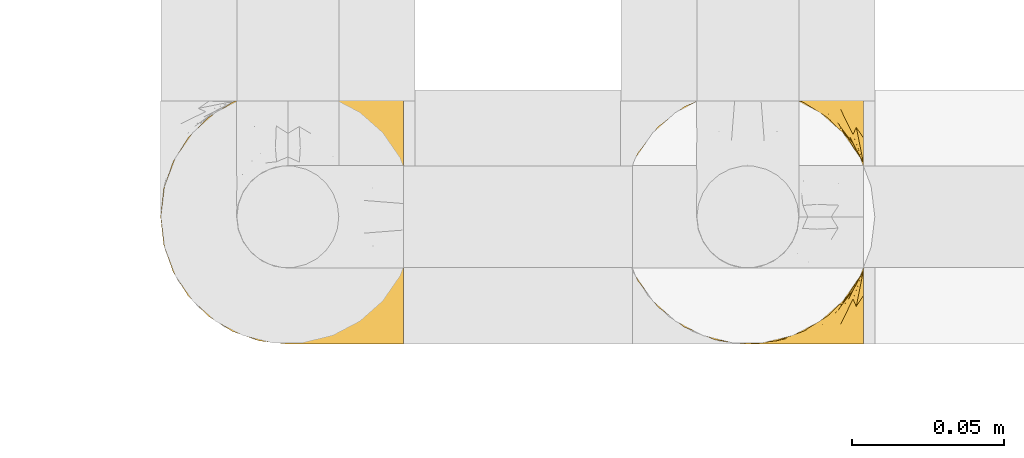
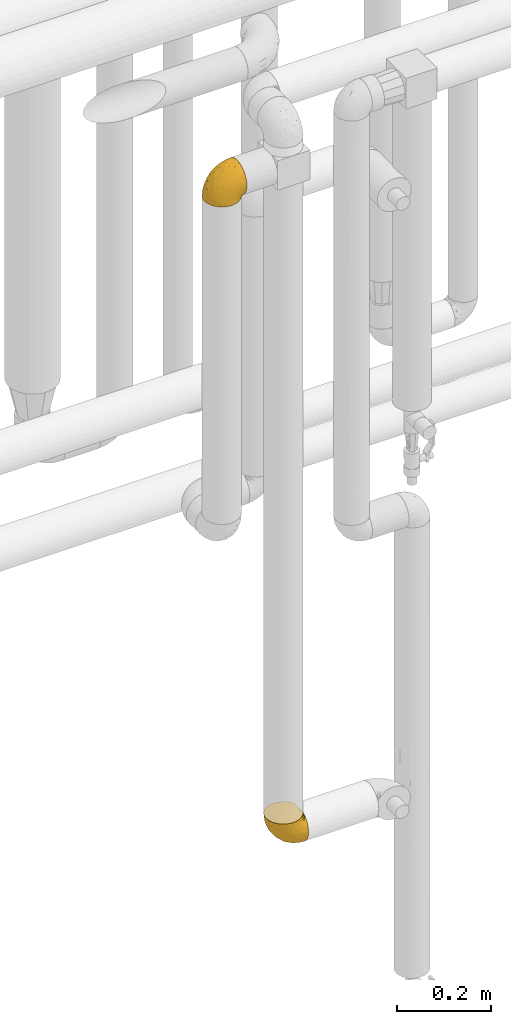
# One storey, part 444 of 827: 2 coverings.
"""IFC2X3 building model written with IfcOpenShell, lengths in millimetres."""

from ifc_helpers import new_model, entity, si_unit, converted_unit, derived_unit, direction, frame, origin, place, context, subcontext, project, spatial, faceted_brep, element, save


model = new_model("IFC2X3")

# Units and contexts
model_context = context("Model", 3, precision=0.01, world=origin(), true_north=direction((6.12303176911189e-17, 1.0)))
body_context = subcontext(model_context, "Body", "Model", "MODEL_VIEW")
ifc_project = project(units=[si_unit("LENGTHUNIT", "METRE", prefix="MILLI"), si_unit("AREAUNIT", "SQUARE_METRE"), si_unit("VOLUMEUNIT", "CUBIC_METRE"), converted_unit("PLANEANGLEUNIT", "DEGREE", entity("IfcRatioMeasure", 0.0174532925199433), si_unit("PLANEANGLEUNIT", "RADIAN"), dimensions=[0, 0, 0, 0, 0, 0, 0]), si_unit("MASSUNIT", "GRAM", prefix="KILO"), derived_unit("MASSDENSITYUNIT", [(si_unit("MASSUNIT", "GRAM", prefix="KILO"), 1), (si_unit("LENGTHUNIT", "METRE"), -3)]), derived_unit("MOMENTOFINERTIAUNIT", [(si_unit("LENGTHUNIT", "METRE"), 4)]), si_unit("TIMEUNIT", "SECOND"), si_unit("FREQUENCYUNIT", "HERTZ"), si_unit("THERMODYNAMICTEMPERATUREUNIT", "DEGREE_CELSIUS"), derived_unit("THERMALTRANSMITTANCEUNIT", [(si_unit("MASSUNIT", "GRAM", prefix="KILO"), 1), (si_unit("THERMODYNAMICTEMPERATUREUNIT", "KELVIN"), -1), (si_unit("TIMEUNIT", "SECOND"), -3)]), derived_unit("VOLUMETRICFLOWRATEUNIT", [(si_unit("LENGTHUNIT", "METRE"), 3), (si_unit("TIMEUNIT", "SECOND"), -1)]), derived_unit("MASSFLOWRATEUNIT", [(si_unit("MASSUNIT", "GRAM", prefix="KILO"), 1), (si_unit("TIMEUNIT", "SECOND"), -1)]), derived_unit("ROTATIONALFREQUENCYUNIT", [(si_unit("TIMEUNIT", "SECOND"), -1)]), si_unit("ELECTRICCURRENTUNIT", "AMPERE"), si_unit("ELECTRICVOLTAGEUNIT", "VOLT"), si_unit("POWERUNIT", "WATT"), si_unit("FORCEUNIT", "NEWTON", prefix="KILO"), si_unit("ILLUMINANCEUNIT", "LUX"), si_unit("LUMINOUSFLUXUNIT", "LUMEN"), si_unit("LUMINOUSINTENSITYUNIT", "CANDELA"), derived_unit("USERDEFINED", [(si_unit("MASSUNIT", "GRAM", prefix="KILO"), -1), (si_unit("LENGTHUNIT", "METRE"), -2), (si_unit("TIMEUNIT", "SECOND"), 3), (si_unit("LUMINOUSFLUXUNIT", "LUMEN"), 1)]), derived_unit("LINEARVELOCITYUNIT", [(si_unit("LENGTHUNIT", "METRE"), 1), (si_unit("TIMEUNIT", "SECOND"), -1)]), si_unit("PRESSUREUNIT", "PASCAL"), derived_unit("USERDEFINED", [(si_unit("LENGTHUNIT", "METRE"), -2), (si_unit("MASSUNIT", "GRAM", prefix="KILO"), 1), (si_unit("TIMEUNIT", "SECOND"), -2)]), derived_unit("LINEARFORCEUNIT", [(si_unit("MASSUNIT", "GRAM", prefix="KILO"), 1), (si_unit("LENGTHUNIT", "METRE"), 1), (si_unit("TIMEUNIT", "SECOND"), -2), (si_unit("LENGTHUNIT", "METRE"), -1)]), derived_unit("PLANARFORCEUNIT", [(si_unit("MASSUNIT", "GRAM", prefix="KILO"), 1), (si_unit("LENGTHUNIT", "METRE"), 1), (si_unit("TIMEUNIT", "SECOND"), -2), (si_unit("LENGTHUNIT", "METRE"), -2)])], contexts=[model_context])

# Site, building, storey
site_placement = place(None, origin())
site = spatial("IfcSite", under=ifc_project, at=site_placement, CompositionType="ELEMENT")
building_placement = place(site_placement, origin())
building = spatial("IfcBuilding", under=site, at=building_placement, CompositionType="ELEMENT")
storey_placement = place(building_placement, frame((0.0, 0.0, 28200.0)))
storey = spatial("IfcBuildingStorey", under=building, at=storey_placement, Name="08", CompositionType="ELEMENT", Elevation=28200.0)

# Coverings
covering_1_placement = place(storey_placement, frame((58981.69, 15400.76, 827.07)))
element("IfcCovering", 1, at=covering_1_placement, inside=storey, Name=":ADSK_", ObjectType=":ADSK_", PredefinedType="INSULATION", context=body_context, shape_type="Brep", body=[
    faceted_brep([(81.45, 5.74, 25.28), (81.45, 10.73, 17.35), (81.45, 17.36, 10.72), (81.45, 25.29, 5.74), (81.45, 34.14, 2.64), (81.45, 43.45, 1.6), (81.45, 52.76, 2.65), (81.45, 61.61, 5.74), (81.45, 69.54, 10.73), (81.45, 76.17, 17.36), (81.45, 81.15, 25.29), (81.45, 84.25, 34.14), (81.45, 85.3, 43.45), (81.45, 84.23, 52.82), (81.45, 81.1, 61.71), (81.45, 76.06, 69.67), (81.45, 69.36, 76.31), (81.45, 61.36, 81.27), (81.45, 60.44, 81.27), (81.45, 59.52, 81.27), (81.45, 58.72, 81.27), (81.45, 57.4, 81.27), (81.45, 56.08, 81.27), (81.45, 54.76, 81.27), (81.45, 53.44, 81.27), (81.45, 52.12, 81.27), (81.45, 50.8, 81.27), (81.45, 49.47, 81.27), (81.45, 48.15, 81.27), (81.45, 46.83, 81.27), (81.45, 45.51, 81.27), (81.45, 44.19, 81.27), (81.45, 42.87, 81.27), (81.45, 41.55, 81.27), (81.45, 40.23, 81.27), (81.45, 39.31, 81.27), (81.45, 38.39, 81.27), (81.45, 37.48, 81.27), (81.45, 36.56, 81.27), (81.45, 35.64, 81.27), (81.45, 34.72, 81.27), (81.45, 33.8, 81.27), (81.45, 32.88, 81.27), (81.45, 31.96, 81.27), (81.45, 31.05, 81.27), (81.45, 30.13, 81.27), (81.45, 29.21, 81.27), (81.45, 28.29, 81.27), (81.45, 27.37, 81.27), (81.45, 26.45, 81.27), (81.45, 25.53, 81.27), (81.45, 17.52, 76.3), (81.45, 10.82, 69.66), (81.45, 5.78, 61.69), (81.45, 2.65, 52.8), (81.45, 1.6, 43.45), (81.45, 2.65, 34.13), (76.3, 69.37, 81.45), (69.67, 76.06, 81.45), (61.7, 81.1, 81.45), (52.81, 84.23, 81.45), (43.45, 85.3, 81.45), (32.61, 83.87, 81.45), (22.52, 79.69, 81.45), (13.85, 73.04, 81.45), (7.2, 64.37, 81.45), (3.02, 54.28, 81.45), (1.6, 43.45, 81.45), (3.02, 32.61, 81.45), (7.2, 22.52, 81.45), (13.85, 13.85, 81.45), (22.52, 7.2, 81.45), (32.61, 3.02, 81.45), (43.45, 1.6, 81.45), (52.81, 2.66, 81.45), (61.7, 5.79, 81.45), (69.67, 10.83, 81.45), (76.3, 17.52, 81.45), (81.27, 25.53, 81.45), (81.27, 26.45, 81.45), (81.27, 27.77, 81.45), (81.27, 28.89, 81.45), (81.27, 30.01, 81.45), (81.27, 31.13, 81.45), (81.27, 32.25, 81.45), (81.27, 33.37, 81.45), (81.27, 34.49, 81.45), (81.27, 35.61, 81.45), (81.27, 36.73, 81.45), (81.27, 37.85, 81.45), (81.27, 38.97, 81.45), (81.27, 40.09, 81.45), (81.27, 41.21, 81.45), (81.27, 42.33, 81.45), (81.27, 43.45, 81.45), (81.27, 44.77, 81.45), (81.27, 46.09, 81.45), (81.27, 47.41, 81.45), (81.27, 48.73, 81.45), (81.27, 50.05, 81.45), (81.27, 51.37, 81.45), (81.27, 52.69, 81.45), (81.27, 54.01, 81.45), (81.27, 54.93, 81.45), (81.27, 55.85, 81.45), (81.27, 56.76, 81.45), (81.27, 57.68, 81.45), (81.27, 58.6, 81.45), (81.27, 59.52, 81.45), (81.27, 60.44, 81.45), (81.27, 61.36, 81.45), (81.31, 32.81, 81.33), (81.33, 31.73, 81.32), (81.31, 50.71, 81.33), (81.32, 51.76, 81.32), (81.31, 42.89, 81.33), (81.32, 41.81, 81.32), (81.32, 25.53, 81.32), (81.32, 26.91, 81.32), (81.32, 40.71, 81.32), (81.32, 60.15, 81.32), (81.32, 39.53, 81.32), (81.32, 57.22, 81.32), (81.3, 58.17, 81.34), (81.32, 47.12, 81.32), (81.33, 33.93, 81.31), (81.31, 35.05, 81.33), (81.33, 46.09, 81.31), (81.32, 45.02, 81.32), (81.32, 43.95, 81.33), (81.32, 59.12, 81.32), (81.31, 38.49, 81.33), (81.32, 49.68, 81.32), (81.31, 53.35, 81.33), (81.32, 54.4, 81.32), (81.32, 56.2, 81.32), (81.32, 36.2, 81.32), (81.33, 37.29, 81.31), (81.32, 30.57, 81.32), (81.31, 29.45, 81.33), (81.33, 28.01, 81.31), (81.32, 61.36, 81.32), (81.36, 25.53, 81.3), (81.4, 25.53, 81.29), (81.4, 61.36, 81.29), (81.36, 61.36, 81.3), (81.29, 25.53, 81.4), (81.3, 25.53, 81.36), (81.3, 61.36, 81.36), (81.29, 61.36, 81.4), (81.35, 55.3, 81.3), (81.31, 48.18, 81.33), (58.5, 82.92, 74.06), (71.95, 85.3, 45.99), (74.57, 82.92, 58.35), (73.93, 78.8, 67.76), (78.18, 78.8, 66.18), (78.04, 70.46, 76.46), (76.23, 71.16, 77.33), (45.99, 85.3, 71.95), (74.01, 76.1, 72.25), (73.57, 72.9, 78.91), (66.66, 78.81, 76.42), (79.09, 72.89, 73.52), (73.14, 74.06, 76.9), (60.34, 83.71, 65.25), (48.54, 85.3, 62.45), (45.36, 85.3, 74.31), (67.22, 83.61, 59.38), (62.45, 85.3, 48.54), (68.67, 80.61, 67.72), (55.49, 85.3, 55.49), (77.84, 67.83, 79.73), (68.16, 78.81, 73.23), (74.31, 85.3, 45.36), (38.78, 54.78, 15.81), (62.1, 57.27, 6.4), (50.89, 43.45, 7.67), (36.91, 84.45, 68.46), (40.37, 84.39, 59.33), (27.86, 77.16, 48.7), (15.77, 68.92, 53.94), (20.13, 76.65, 65.02), (31.54, 82.11, 60.77), (28.25, 82.11, 72.07), (57.26, 78.88, 26.25), (69.99, 78.88, 22.29), (64.58, 73.04, 16.0), (50.64, 84.47, 46.93), (51.97, 65.72, 14.19), (5.72, 51.16, 58.46), (7.42, 59.46, 61.51), (66.14, 43.45, 4.64), (11.35, 68.92, 68.93), (21.64, 51.18, 29.62), (28.57, 57.42, 24.85), (55.38, 83.48, 38.55), (68.51, 82.95, 31.27), (67.48, 65.72, 9.35), (40.78, 78.97, 37.15), (41.53, 82.64, 47.07), (46.11, 75.14, 26.49), (40.32, 68.58, 23.01), (38.36, 61.95, 19.4), (11.84, 58.11, 48.06), (12.56, 51.07, 42.46), (7.67, 43.45, 50.89), (19.39, 58.51, 35.78), (24.98, 43.45, 24.98), (37.94, 43.45, 16.33), (4.64, 43.45, 66.14), (28.09, 65.68, 30.96), (23.73, 70.41, 41.83), (34.03, 73.04, 33.28), (16.33, 43.45, 37.94), (29.29, 4.78, 67.39), (5.77, 35.48, 58.47), (21.44, 29.45, 32.5), (38.8, 32.11, 15.79), (64.58, 13.86, 15.99), (67.49, 21.19, 9.34), (22.9, 10.24, 56.91), (12.54, 17.97, 63.5), (20.04, 18.88, 44.08), (57.26, 8.01, 26.24), (69.99, 8.01, 22.27), (68.51, 3.95, 31.26), (34.54, 22.45, 23.95), (38.81, 2.4, 63.79), (48.54, 1.6, 62.45), (45.99, 1.6, 71.95), (74.31, 1.6, 45.36), (5.36, 29.05, 67.83), (18.96, 10.24, 70.28), (12.79, 35.7, 42.11), (62.11, 29.63, 6.39), (33.14, 8.75, 43.54), (33.44, 4.54, 58.03), (51.98, 21.19, 14.18), (43.42, 2.28, 56.34), (48.62, 2.53, 48.09), (62.45, 1.6, 48.54), (55.49, 1.6, 55.49), (49.68, 13.86, 21.78), (55.37, 3.41, 38.54), (71.95, 1.6, 45.99), (36.37, 2.35, 72.79), (34.04, 13.86, 33.26), (44.1, 7.35, 35.53), (9.99, 27.43, 53.66), (26.41, 13.39, 43.03), (39.19, 4.32, 49.68), (58.5, 3.97, 74.06), (67.22, 3.27, 59.37), (74.57, 3.97, 58.34), (73.92, 8.08, 67.75), (73.57, 13.99, 78.91), (73.14, 12.83, 76.9), (66.19, 8.08, 78.08), (68.16, 8.08, 73.23), (77.84, 19.06, 79.73), (76.23, 15.74, 77.34), (79.08, 13.98, 73.51), (78.04, 16.42, 76.45), (77.18, 8.08, 66.41), (68.66, 6.27, 67.7), (74.0, 10.78, 72.24), (60.34, 3.18, 65.25)], [[[0, 1, 2, 3, 4, 5, 6, 7, 8, 9, 10, 11, 12, 13, 14, 15, 16, 17, 18, 19, 20, 21, 22, 23, 24, 25, 26, 27, 28, 29, 30, 31, 32, 33, 34, 35, 36, 37, 38, 39, 40, 41, 42, 43, 44, 45, 46, 47, 48, 49, 50, 51, 52, 53, 54, 55, 56]], [[57, 58, 59, 60, 61, 62, 63, 64, 65, 66, 67, 68, 69, 70, 71, 72, 73, 74, 75, 76, 77, 78, 79, 80, 81, 82, 83, 84, 85, 86, 87, 88, 89, 90, 91, 92, 93, 94, 95, 96, 97, 98, 99, 100, 101, 102, 103, 104, 105, 106, 107, 108, 109, 110]], [[111, 84, 112]], [[113, 26, 114]], [[114, 101, 100]], [[115, 93, 116]], [[79, 117, 118]], [[33, 116, 119]], [[117, 49, 118]], [[19, 18, 120]], [[119, 121, 34]], [[122, 21, 123]], [[97, 96, 124]], [[86, 125, 126]], [[116, 92, 119]], [[127, 96, 128]], [[32, 129, 115]], [[19, 120, 130]], [[121, 90, 131]], [[94, 115, 129]], [[115, 116, 32]], [[118, 49, 48]], [[113, 99, 132]], [[133, 114, 25]], [[24, 134, 133]], [[135, 22, 122]], [[136, 137, 88]], [[84, 83, 112]], [[138, 82, 139]], [[130, 20, 19]], [[118, 48, 140]], [[81, 140, 139]], [[123, 21, 20]], [[141, 120, 18]], [[139, 82, 81]], [[130, 107, 123]], [[49, 117, 142, 143, 50]], [[18, 17, 144, 145, 141]], [[79, 78, 146, 147, 117]], [[109, 141, 148, 149, 110]], [[102, 133, 134]], [[105, 135, 122]], [[118, 80, 79]], [[120, 109, 108]], [[80, 118, 140]], [[47, 46, 140, 48]], [[81, 80, 140]], [[44, 112, 138]], [[93, 115, 94]], [[46, 139, 140]], [[46, 45, 139]], [[139, 45, 138]], [[138, 112, 83]], [[85, 84, 111]], [[112, 43, 111]], [[83, 82, 138]], [[106, 122, 123]], [[105, 122, 106]], [[21, 122, 22]], [[124, 29, 28]], [[33, 32, 116]], [[128, 129, 31]], [[32, 31, 129]], [[34, 33, 119]], [[116, 93, 92]], [[129, 95, 94]], [[95, 129, 128]], [[41, 40, 125, 42]], [[119, 91, 121]], [[36, 35, 131, 37]], [[137, 131, 89]], [[121, 131, 35]], [[90, 121, 91]], [[119, 92, 91]], [[136, 126, 39]], [[125, 86, 85]], [[42, 125, 111]], [[85, 111, 125]], [[150, 23, 22]], [[130, 108, 107]], [[130, 123, 20]], [[107, 106, 123]], [[137, 37, 131]], [[136, 38, 137]], [[89, 88, 137]], [[131, 90, 89]], [[124, 151, 97]], [[40, 39, 126]], [[87, 126, 136]], [[86, 126, 87]], [[136, 88, 87]], [[40, 126, 125]], [[39, 38, 136]], [[95, 128, 96]], [[30, 128, 31]], [[29, 124, 127]], [[127, 128, 30]], [[151, 124, 28]], [[127, 30, 29]], [[127, 124, 96]], [[151, 98, 97]], [[45, 44, 138]], [[26, 113, 132]], [[113, 100, 99]], [[132, 151, 27]], [[27, 26, 132]], [[26, 25, 114]], [[100, 113, 114]], [[101, 133, 102]], [[133, 101, 114]], [[28, 27, 151]], [[132, 99, 98]], [[23, 134, 24]], [[25, 24, 133]], [[134, 23, 150]], [[135, 104, 150]], [[150, 104, 103]], [[103, 102, 134]], [[130, 120, 108]], [[109, 120, 141]], [[42, 111, 43]], [[112, 44, 43]], [[104, 135, 105]], [[134, 150, 103]], [[135, 150, 22]], [[35, 34, 121]], [[137, 38, 37]], [[98, 151, 132]], [[59, 152, 60]], [[13, 153, 154]], [[155, 156, 154]], [[157, 158, 141]], [[159, 60, 152]], [[160, 157, 155]], [[161, 162, 58]], [[58, 162, 59]], [[144, 16, 163]], [[58, 57, 161]], [[162, 161, 164]], [[157, 163, 155]], [[163, 16, 15]], [[57, 149, 161]], [[152, 165, 166]], [[157, 144, 163]], [[60, 159, 167, 61]], [[156, 14, 154]], [[163, 156, 155]], [[155, 154, 168]], [[168, 154, 169]], [[155, 170, 160]], [[57, 110, 149]], [[144, 17, 16]], [[156, 15, 14]], [[171, 165, 168]], [[158, 164, 172]], [[14, 13, 154]], [[157, 141, 145, 144]], [[173, 164, 158]], [[173, 160, 170]], [[171, 166, 165]], [[168, 165, 170]], [[168, 169, 171]], [[152, 173, 165]], [[170, 155, 168]], [[165, 173, 170]], [[160, 173, 158]], [[172, 149, 148]], [[148, 141, 158]], [[158, 157, 160]], [[152, 166, 159]], [[173, 152, 162]], [[59, 162, 152]], [[13, 12, 174, 153]], [[153, 169, 154]], [[15, 156, 163]], [[162, 164, 173]], [[172, 164, 161]], [[149, 172, 161]], [[158, 172, 148]], [[175, 176, 177]], [[178, 166, 179]], [[180, 181, 182]], [[183, 184, 178]], [[185, 186, 187]], [[171, 188, 179]], [[174, 12, 11]], [[189, 176, 175]], [[190, 66, 191]], [[176, 6, 192]], [[193, 65, 64]], [[63, 184, 182]], [[63, 182, 64]], [[65, 193, 191]], [[184, 63, 62]], [[175, 194, 195]], [[196, 169, 197]], [[174, 11, 197]], [[8, 7, 198]], [[187, 9, 8]], [[197, 169, 153, 174]], [[197, 11, 10]], [[186, 197, 10]], [[199, 180, 200]], [[197, 185, 196]], [[201, 189, 202]], [[201, 187, 189]], [[195, 203, 175]], [[191, 204, 190]], [[176, 7, 6]], [[177, 176, 192]], [[189, 198, 176]], [[65, 191, 66]], [[198, 187, 8]], [[205, 206, 190]], [[9, 186, 10]], [[181, 207, 204]], [[208, 175, 177, 209]], [[66, 190, 210]], [[211, 212, 213]], [[190, 204, 205]], [[180, 182, 183]], [[193, 182, 181]], [[62, 61, 167]], [[196, 185, 199]], [[196, 200, 188]], [[6, 5, 192]], [[176, 198, 7]], [[187, 198, 189]], [[187, 186, 9]], [[197, 186, 185]], [[200, 180, 183]], [[180, 213, 212]], [[179, 183, 178]], [[185, 201, 199]], [[210, 190, 206]], [[210, 67, 66]], [[205, 204, 207]], [[194, 205, 207]], [[194, 214, 205]], [[195, 194, 207]], [[208, 194, 175]], [[207, 211, 195]], [[202, 203, 211]], [[212, 207, 181]], [[202, 211, 213]], [[201, 202, 213]], [[189, 175, 203]], [[199, 201, 213]], [[187, 201, 185]], [[180, 199, 213]], [[196, 199, 200]], [[211, 203, 195]], [[189, 203, 202]], [[207, 212, 211]], [[180, 212, 181]], [[214, 194, 208]], [[214, 206, 205]], [[196, 188, 169]], [[181, 204, 191]], [[182, 193, 64]], [[191, 193, 181]], [[178, 62, 167]], [[182, 184, 183]], [[62, 178, 184]], [[178, 167, 159, 166]], [[171, 179, 166]], [[200, 183, 179]], [[179, 188, 200]], [[169, 188, 171]], [[71, 215, 72]], [[206, 216, 210]], [[217, 208, 218]], [[216, 68, 210]], [[219, 220, 2]], [[221, 222, 223]], [[224, 225, 226]], [[227, 223, 217]], [[228, 229, 230]], [[56, 231, 226]], [[232, 222, 69]], [[56, 55, 231]], [[70, 233, 71]], [[71, 233, 215]], [[0, 56, 226]], [[208, 217, 234]], [[218, 177, 235]], [[221, 236, 237]], [[238, 220, 219]], [[1, 219, 2]], [[68, 216, 232]], [[235, 3, 220]], [[235, 192, 4]], [[1, 0, 225]], [[228, 239, 229]], [[240, 241, 242]], [[243, 238, 219]], [[224, 226, 244]], [[226, 241, 244]], [[3, 235, 4]], [[69, 222, 70]], [[225, 219, 1]], [[218, 235, 238]], [[243, 219, 224]], [[218, 227, 217]], [[3, 2, 220]], [[218, 208, 209, 177]], [[226, 231, 245, 241]], [[215, 228, 246]], [[247, 248, 236]], [[248, 224, 244]], [[223, 222, 249]], [[233, 222, 221]], [[242, 239, 240]], [[248, 247, 243]], [[217, 223, 249]], [[250, 247, 236]], [[216, 234, 249]], [[218, 238, 227]], [[192, 235, 177]], [[192, 5, 4]], [[72, 246, 73]], [[235, 220, 238]], [[226, 225, 0]], [[219, 225, 224]], [[240, 248, 244]], [[239, 242, 229]], [[236, 248, 251]], [[68, 67, 210]], [[234, 216, 206]], [[216, 249, 232]], [[234, 206, 214, 208]], [[249, 234, 217]], [[222, 232, 249]], [[69, 68, 232]], [[246, 228, 230]], [[237, 228, 215]], [[243, 227, 238]], [[223, 227, 247]], [[73, 246, 230]], [[215, 246, 72]], [[248, 243, 224]], [[227, 243, 247]], [[237, 236, 251]], [[250, 221, 223]], [[222, 233, 70]], [[215, 233, 221]], [[221, 237, 215]], [[239, 237, 251]], [[237, 239, 228]], [[239, 251, 240]], [[248, 240, 251]], [[241, 240, 244]], [[221, 250, 236]], [[223, 247, 250]], [[74, 230, 252]], [[253, 254, 255]], [[146, 77, 256]], [[257, 258, 259]], [[260, 256, 257]], [[260, 261, 147]], [[75, 74, 252]], [[51, 143, 262]], [[263, 143, 142, 117]], [[256, 77, 76]], [[252, 258, 75]], [[253, 241, 254]], [[254, 245, 54]], [[258, 256, 76]], [[53, 52, 264]], [[255, 265, 253]], [[254, 264, 255]], [[255, 264, 262]], [[75, 258, 76]], [[265, 255, 266]], [[255, 262, 263]], [[51, 50, 143]], [[54, 245, 231, 55]], [[51, 262, 52]], [[253, 267, 242]], [[254, 54, 53]], [[266, 259, 265]], [[146, 78, 77]], [[263, 117, 261]], [[146, 256, 260]], [[257, 259, 261]], [[267, 253, 265]], [[229, 267, 252]], [[242, 267, 229]], [[242, 241, 253]], [[252, 267, 259]], [[255, 263, 266]], [[259, 267, 265]], [[261, 117, 147]], [[263, 261, 266]], [[259, 266, 261]], [[230, 74, 73]], [[230, 229, 252]], [[259, 258, 252]], [[254, 241, 245]], [[53, 264, 254]], [[52, 262, 264]], [[143, 263, 262]], [[258, 257, 256]], [[261, 260, 257]], [[146, 260, 147]]]),
])
covering_2_placement = place(storey_placement, frame((58830.44, 15400.76, 2560.4)))
element("IfcCovering", 2, at=covering_2_placement, inside=storey, Name=":ADSK_", ObjectType=":ADSK_", PredefinedType="INSULATION", context=body_context, shape_type="Brep", body=[
    faceted_brep([(25.28, 5.74, 1.6), (17.35, 10.73, 1.6), (10.72, 17.36, 1.6), (5.74, 25.29, 1.6), (2.64, 34.14, 1.6), (1.6, 43.45, 1.6), (2.65, 52.76, 1.6), (5.74, 61.61, 1.6), (10.73, 69.54, 1.6), (17.36, 76.17, 1.6), (25.29, 81.15, 1.6), (34.14, 84.25, 1.6), (43.45, 85.3, 1.6), (52.82, 84.23, 1.6), (61.71, 81.1, 1.6), (69.67, 76.06, 1.6), (76.31, 69.36, 1.6), (81.27, 61.36, 1.6), (81.27, 60.44, 1.6), (81.27, 59.52, 1.6), (81.27, 58.72, 1.6), (81.27, 57.4, 1.6), (81.27, 56.08, 1.6), (81.27, 54.76, 1.6), (81.27, 53.44, 1.6), (81.27, 52.12, 1.6), (81.27, 50.8, 1.6), (81.27, 49.47, 1.6), (81.27, 48.15, 1.6), (81.27, 46.83, 1.6), (81.27, 45.51, 1.6), (81.27, 44.19, 1.6), (81.27, 42.87, 1.6), (81.27, 41.55, 1.6), (81.27, 40.23, 1.6), (81.27, 39.31, 1.6), (81.27, 38.39, 1.6), (81.27, 37.48, 1.6), (81.27, 36.56, 1.6), (81.27, 35.64, 1.6), (81.27, 34.72, 1.6), (81.27, 33.8, 1.6), (81.27, 32.88, 1.6), (81.27, 31.96, 1.6), (81.27, 31.05, 1.6), (81.27, 30.13, 1.6), (81.27, 29.21, 1.6), (81.27, 28.29, 1.6), (81.27, 27.37, 1.6), (81.27, 26.45, 1.6), (81.27, 25.53, 1.6), (76.3, 17.52, 1.6), (69.66, 10.82, 1.6), (61.69, 5.78, 1.6), (52.8, 2.65, 1.6), (43.45, 1.6, 1.6), (34.13, 2.65, 1.6), (81.45, 69.37, 6.74), (81.45, 76.06, 13.37), (81.45, 81.1, 21.34), (81.45, 84.23, 30.23), (81.45, 85.3, 39.6), (81.45, 83.87, 50.43), (81.45, 79.69, 60.52), (81.45, 73.04, 69.19), (81.45, 64.37, 75.84), (81.45, 54.28, 80.02), (81.45, 43.45, 81.45), (81.45, 32.61, 80.02), (81.45, 22.52, 75.84), (81.45, 13.85, 69.19), (81.45, 7.2, 60.52), (81.45, 3.02, 50.43), (81.45, 1.6, 39.6), (81.45, 2.66, 30.23), (81.45, 5.79, 21.34), (81.45, 10.83, 13.37), (81.45, 17.52, 6.74), (81.45, 25.53, 1.77), (81.45, 26.45, 1.77), (81.45, 27.77, 1.77), (81.45, 28.89, 1.77), (81.45, 30.01, 1.77), (81.45, 31.13, 1.77), (81.45, 32.25, 1.77), (81.45, 33.37, 1.77), (81.45, 34.49, 1.77), (81.45, 35.61, 1.77), (81.45, 36.73, 1.77), (81.45, 37.85, 1.77), (81.45, 38.97, 1.77), (81.45, 40.09, 1.77), (81.45, 41.21, 1.77), (81.45, 42.33, 1.77), (81.45, 43.45, 1.77), (81.45, 44.77, 1.77), (81.45, 46.09, 1.77), (81.45, 47.41, 1.77), (81.45, 48.73, 1.77), (81.45, 50.05, 1.77), (81.45, 51.37, 1.77), (81.45, 52.69, 1.77), (81.45, 54.01, 1.77), (81.45, 54.93, 1.77), (81.45, 55.85, 1.77), (81.45, 56.76, 1.77), (81.45, 57.68, 1.77), (81.45, 58.6, 1.77), (81.45, 59.52, 1.77), (81.45, 60.44, 1.77), (81.45, 61.36, 1.77), (81.33, 32.81, 1.73), (81.32, 31.73, 1.72), (81.33, 50.71, 1.73), (81.32, 51.76, 1.72), (81.33, 42.89, 1.73), (81.32, 41.81, 1.73), (81.32, 25.53, 1.72), (81.32, 26.91, 1.72), (81.32, 40.71, 1.72), (81.32, 60.15, 1.72), (81.32, 39.53, 1.72), (81.32, 57.22, 1.73), (81.34, 58.17, 1.74), (81.32, 47.12, 1.72), (81.31, 33.93, 1.71), (81.33, 35.05, 1.73), (81.31, 46.09, 1.71), (81.32, 45.02, 1.72), (81.33, 43.95, 1.73), (81.32, 59.12, 1.72), (81.33, 38.49, 1.73), (81.32, 49.68, 1.72), (81.33, 53.35, 1.73), (81.32, 54.4, 1.72), (81.32, 56.2, 1.72), (81.32, 36.2, 1.72), (81.31, 37.29, 1.71), (81.32, 30.57, 1.72), (81.33, 29.45, 1.73), (81.31, 28.01, 1.71), (81.32, 61.36, 1.72), (81.3, 25.53, 1.68), (81.29, 25.53, 1.64), (81.29, 61.36, 1.64), (81.3, 61.36, 1.68), (81.4, 25.53, 1.75), (81.4, 61.36, 1.75), (81.36, 61.36, 1.74), (81.36, 25.53, 1.74), (81.3, 55.3, 1.7), (81.33, 48.18, 1.73), (74.06, 82.92, 24.54), (45.99, 85.3, 11.1), (58.35, 82.92, 8.47), (67.76, 78.8, 9.11), (66.18, 78.8, 4.86), (76.46, 70.46, 5.0), (77.33, 71.16, 6.81), (71.95, 85.3, 37.05), (72.25, 76.1, 9.03), (78.91, 72.9, 9.47), (76.42, 78.81, 16.39), (73.52, 72.89, 3.95), (76.9, 74.06, 9.9), (65.25, 83.71, 22.7), (62.45, 85.3, 34.5), (74.31, 85.3, 37.68), (59.38, 83.61, 15.82), (48.54, 85.3, 20.6), (67.72, 80.61, 14.37), (55.49, 85.3, 27.55), (79.73, 67.83, 5.2), (73.23, 78.81, 14.88), (45.36, 85.3, 8.73), (15.81, 54.78, 44.27), (6.4, 57.27, 20.94), (7.67, 43.45, 32.15), (68.46, 84.45, 46.13), (59.33, 84.39, 42.67), (48.7, 77.16, 55.18), (53.94, 68.92, 67.27), (65.02, 76.65, 62.91), (60.77, 82.11, 51.5), (72.07, 82.11, 54.79), (26.25, 78.88, 25.78), (22.29, 78.88, 13.05), (16.0, 73.04, 18.46), (46.93, 84.47, 32.4), (14.19, 65.72, 31.07), (58.46, 51.16, 77.32), (61.51, 59.46, 75.62), (4.64, 43.45, 16.9), (68.93, 68.92, 71.69), (29.62, 51.18, 61.4), (24.85, 57.42, 54.47), (38.55, 83.48, 27.66), (31.27, 82.95, 14.53), (9.35, 65.72, 15.56), (37.15, 78.97, 42.26), (47.07, 82.64, 41.51), (26.49, 75.14, 36.93), (23.01, 68.58, 42.72), (19.4, 61.95, 44.68), (48.06, 58.11, 71.2), (42.46, 51.07, 70.48), (50.89, 43.45, 75.37), (35.78, 58.51, 63.65), (24.98, 43.45, 58.06), (16.33, 43.45, 45.11), (66.14, 43.45, 78.4), (30.96, 65.68, 54.95), (41.83, 70.41, 59.31), (33.28, 73.04, 49.01), (37.94, 43.45, 66.71), (67.39, 4.78, 53.75), (58.47, 35.48, 77.27), (32.5, 29.45, 61.6), (15.79, 32.11, 44.24), (15.99, 13.86, 18.46), (9.34, 21.19, 15.55), (56.91, 10.24, 60.14), (63.5, 17.97, 70.5), (44.08, 18.88, 63.0), (26.24, 8.01, 25.78), (22.27, 8.01, 13.05), (31.26, 3.95, 14.53), (23.95, 22.45, 48.5), (63.79, 2.4, 44.23), (62.45, 1.6, 34.5), (71.95, 1.6, 37.05), (45.36, 1.6, 8.73), (67.83, 29.05, 77.68), (70.28, 10.24, 64.08), (42.11, 35.7, 70.25), (6.39, 29.63, 20.93), (43.54, 8.75, 49.9), (58.03, 4.54, 49.6), (14.18, 21.19, 31.06), (56.34, 2.28, 39.62), (48.09, 2.53, 34.42), (48.54, 1.6, 20.6), (55.49, 1.6, 27.55), (21.78, 13.86, 33.36), (38.54, 3.41, 27.68), (45.99, 1.6, 11.1), (72.79, 2.35, 46.67), (33.26, 13.86, 49.0), (35.53, 7.35, 38.94), (53.66, 27.43, 73.05), (43.03, 13.39, 56.63), (49.68, 4.32, 43.85), (74.06, 3.97, 24.54), (59.37, 3.27, 15.82), (58.34, 3.97, 8.47), (67.75, 8.08, 9.12), (78.91, 13.99, 9.47), (76.9, 12.83, 9.91), (78.08, 8.08, 16.85), (73.23, 8.08, 14.88), (79.73, 19.06, 5.2), (77.34, 15.74, 6.81), (73.51, 13.98, 3.96), (76.45, 16.42, 5.0), (66.41, 8.08, 5.86), (67.7, 6.27, 14.38), (72.24, 10.78, 9.04), (65.25, 3.18, 22.7)], [[[0, 1, 2, 3, 4, 5, 6, 7, 8, 9, 10, 11, 12, 13, 14, 15, 16, 17, 18, 19, 20, 21, 22, 23, 24, 25, 26, 27, 28, 29, 30, 31, 32, 33, 34, 35, 36, 37, 38, 39, 40, 41, 42, 43, 44, 45, 46, 47, 48, 49, 50, 51, 52, 53, 54, 55, 56]], [[57, 58, 59, 60, 61, 62, 63, 64, 65, 66, 67, 68, 69, 70, 71, 72, 73, 74, 75, 76, 77, 78, 79, 80, 81, 82, 83, 84, 85, 86, 87, 88, 89, 90, 91, 92, 93, 94, 95, 96, 97, 98, 99, 100, 101, 102, 103, 104, 105, 106, 107, 108, 109, 110]], [[111, 84, 112]], [[113, 26, 114]], [[114, 101, 100]], [[115, 93, 116]], [[79, 117, 118]], [[33, 116, 119]], [[117, 49, 118]], [[19, 18, 120]], [[119, 121, 34]], [[122, 21, 123]], [[97, 96, 124]], [[86, 125, 126]], [[116, 92, 119]], [[127, 96, 128]], [[32, 129, 115]], [[19, 120, 130]], [[121, 90, 131]], [[94, 115, 129]], [[115, 116, 32]], [[118, 49, 48]], [[113, 99, 132]], [[133, 114, 25]], [[24, 134, 133]], [[135, 22, 122]], [[136, 137, 88]], [[84, 83, 112]], [[138, 82, 139]], [[130, 20, 19]], [[118, 48, 140]], [[81, 140, 139]], [[123, 21, 20]], [[141, 120, 18]], [[139, 82, 81]], [[130, 107, 123]], [[49, 117, 142, 143, 50]], [[18, 17, 144, 145, 141]], [[79, 78, 146]], [[109, 147, 110]], [[102, 133, 134]], [[105, 135, 122]], [[109, 141, 148, 147]], [[79, 146, 149, 117]], [[118, 80, 79]], [[80, 118, 140]], [[120, 109, 108]], [[47, 46, 140, 48]], [[81, 80, 140]], [[44, 112, 138]], [[93, 115, 94]], [[46, 139, 140]], [[46, 45, 139]], [[139, 45, 138]], [[138, 112, 83]], [[85, 84, 111]], [[112, 43, 111]], [[83, 82, 138]], [[106, 122, 123]], [[105, 122, 106]], [[21, 122, 22]], [[124, 29, 28]], [[33, 32, 116]], [[128, 129, 31]], [[32, 31, 129]], [[34, 33, 119]], [[116, 93, 92]], [[129, 95, 94]], [[95, 129, 128]], [[41, 40, 125, 42]], [[119, 91, 121]], [[36, 35, 131, 37]], [[137, 131, 89]], [[121, 131, 35]], [[90, 121, 91]], [[119, 92, 91]], [[136, 126, 39]], [[125, 86, 85]], [[42, 125, 111]], [[85, 111, 125]], [[150, 23, 22]], [[130, 108, 107]], [[130, 123, 20]], [[107, 106, 123]], [[137, 37, 131]], [[136, 38, 137]], [[89, 88, 137]], [[131, 90, 89]], [[124, 151, 97]], [[40, 39, 126]], [[87, 126, 136]], [[86, 126, 87]], [[136, 88, 87]], [[40, 126, 125]], [[39, 38, 136]], [[95, 128, 96]], [[30, 128, 31]], [[29, 124, 127]], [[127, 128, 30]], [[151, 124, 28]], [[127, 30, 29]], [[127, 124, 96]], [[151, 98, 97]], [[45, 44, 138]], [[26, 113, 132]], [[113, 100, 99]], [[132, 151, 27]], [[27, 26, 132]], [[26, 25, 114]], [[100, 113, 114]], [[101, 133, 102]], [[133, 101, 114]], [[28, 27, 151]], [[132, 99, 98]], [[23, 134, 24]], [[25, 24, 133]], [[134, 23, 150]], [[135, 104, 150]], [[150, 104, 103]], [[103, 102, 134]], [[130, 120, 108]], [[109, 120, 141]], [[42, 111, 43]], [[112, 44, 43]], [[104, 135, 105]], [[134, 150, 103]], [[135, 150, 22]], [[35, 34, 121]], [[137, 38, 37]], [[98, 151, 132]], [[59, 152, 60]], [[13, 153, 154]], [[155, 156, 154]], [[157, 158, 141]], [[159, 60, 152]], [[160, 157, 155]], [[161, 162, 58]], [[58, 162, 59]], [[144, 16, 163]], [[58, 57, 161]], [[162, 161, 164]], [[157, 163, 155]], [[163, 16, 15]], [[57, 147, 161]], [[152, 165, 166]], [[157, 144, 163]], [[60, 159, 167, 61]], [[156, 14, 154]], [[163, 156, 155]], [[155, 154, 168]], [[168, 154, 169]], [[155, 170, 160]], [[57, 110, 147]], [[144, 17, 16]], [[156, 15, 14]], [[171, 165, 168]], [[158, 164, 172]], [[14, 13, 154]], [[157, 141, 145, 144]], [[173, 164, 158]], [[173, 160, 170]], [[171, 166, 165]], [[168, 165, 170]], [[168, 169, 171]], [[152, 173, 165]], [[170, 155, 168]], [[165, 173, 170]], [[160, 173, 158]], [[172, 147, 148]], [[148, 141, 158]], [[158, 157, 160]], [[152, 166, 159]], [[173, 152, 162]], [[59, 162, 152]], [[13, 12, 174, 153]], [[153, 169, 154]], [[15, 156, 163]], [[162, 164, 173]], [[172, 164, 161]], [[147, 172, 161]], [[158, 172, 148]], [[175, 176, 177]], [[178, 166, 179]], [[180, 181, 182]], [[183, 184, 178]], [[185, 186, 187]], [[171, 188, 179]], [[174, 12, 11]], [[189, 176, 175]], [[190, 66, 191]], [[176, 6, 192]], [[193, 65, 64]], [[63, 184, 182]], [[63, 182, 64]], [[65, 193, 191]], [[184, 63, 62]], [[175, 194, 195]], [[196, 169, 197]], [[174, 11, 197]], [[8, 7, 198]], [[187, 9, 8]], [[197, 169, 153, 174]], [[197, 11, 10]], [[186, 197, 10]], [[199, 180, 200]], [[197, 185, 196]], [[201, 189, 202]], [[201, 187, 189]], [[195, 203, 175]], [[191, 204, 190]], [[176, 7, 6]], [[177, 176, 192]], [[189, 198, 176]], [[65, 191, 66]], [[198, 187, 8]], [[205, 206, 190]], [[9, 186, 10]], [[181, 207, 204]], [[208, 175, 177, 209]], [[66, 190, 210]], [[211, 212, 213]], [[190, 204, 205]], [[180, 182, 183]], [[193, 182, 181]], [[62, 61, 167]], [[196, 185, 199]], [[196, 200, 188]], [[6, 5, 192]], [[176, 198, 7]], [[187, 198, 189]], [[187, 186, 9]], [[197, 186, 185]], [[200, 180, 183]], [[180, 213, 212]], [[179, 183, 178]], [[185, 201, 199]], [[210, 190, 206]], [[210, 67, 66]], [[205, 204, 207]], [[194, 205, 207]], [[194, 214, 205]], [[195, 194, 207]], [[208, 194, 175]], [[207, 211, 195]], [[202, 203, 211]], [[212, 207, 181]], [[202, 211, 213]], [[201, 202, 213]], [[189, 175, 203]], [[199, 201, 213]], [[187, 201, 185]], [[180, 199, 213]], [[196, 199, 200]], [[211, 203, 195]], [[189, 203, 202]], [[207, 212, 211]], [[180, 212, 181]], [[214, 194, 208]], [[214, 206, 205]], [[196, 188, 169]], [[181, 204, 191]], [[182, 193, 64]], [[191, 193, 181]], [[178, 62, 167]], [[182, 184, 183]], [[62, 178, 184]], [[178, 167, 159, 166]], [[171, 179, 166]], [[200, 183, 179]], [[179, 188, 200]], [[169, 188, 171]], [[71, 215, 72]], [[206, 216, 210]], [[217, 208, 218]], [[216, 68, 210]], [[219, 220, 2]], [[221, 222, 223]], [[224, 225, 226]], [[227, 223, 217]], [[228, 229, 230]], [[56, 231, 226]], [[232, 222, 69]], [[56, 55, 231]], [[70, 233, 71]], [[71, 233, 215]], [[0, 56, 226]], [[208, 217, 234]], [[218, 177, 235]], [[221, 236, 237]], [[238, 220, 219]], [[1, 219, 2]], [[68, 216, 232]], [[235, 3, 220]], [[235, 192, 4]], [[1, 0, 225]], [[228, 239, 229]], [[240, 241, 242]], [[243, 238, 219]], [[224, 226, 244]], [[226, 241, 244]], [[3, 235, 4]], [[69, 222, 70]], [[225, 219, 1]], [[218, 235, 238]], [[243, 219, 224]], [[218, 227, 217]], [[3, 2, 220]], [[218, 208, 209, 177]], [[226, 231, 245, 241]], [[215, 228, 246]], [[247, 248, 236]], [[248, 224, 244]], [[223, 222, 249]], [[233, 222, 221]], [[242, 239, 240]], [[248, 247, 243]], [[217, 223, 249]], [[250, 247, 236]], [[216, 234, 249]], [[218, 238, 227]], [[192, 235, 177]], [[192, 5, 4]], [[72, 246, 73]], [[235, 220, 238]], [[226, 225, 0]], [[219, 225, 224]], [[240, 248, 244]], [[239, 242, 229]], [[236, 248, 251]], [[68, 67, 210]], [[234, 216, 206]], [[216, 249, 232]], [[234, 206, 214, 208]], [[249, 234, 217]], [[222, 232, 249]], [[69, 68, 232]], [[246, 228, 230]], [[237, 228, 215]], [[243, 227, 238]], [[223, 227, 247]], [[73, 246, 230]], [[215, 246, 72]], [[248, 243, 224]], [[227, 243, 247]], [[237, 236, 251]], [[250, 221, 223]], [[222, 233, 70]], [[215, 233, 221]], [[221, 237, 215]], [[239, 237, 251]], [[237, 239, 228]], [[239, 251, 240]], [[248, 240, 251]], [[241, 240, 244]], [[221, 250, 236]], [[223, 247, 250]], [[74, 230, 252]], [[253, 254, 255]], [[146, 77, 256]], [[257, 258, 259]], [[260, 256, 257]], [[260, 261, 149]], [[75, 74, 252]], [[51, 143, 262]], [[263, 143, 142, 117]], [[256, 77, 76]], [[252, 258, 75]], [[253, 241, 254]], [[254, 245, 54]], [[258, 256, 76]], [[53, 52, 264]], [[255, 265, 253]], [[254, 264, 255]], [[255, 264, 262]], [[75, 258, 76]], [[265, 255, 266]], [[255, 262, 263]], [[51, 50, 143]], [[54, 245, 231, 55]], [[51, 262, 52]], [[253, 267, 242]], [[254, 54, 53]], [[266, 259, 265]], [[146, 78, 77]], [[263, 117, 261]], [[146, 256, 260]], [[257, 259, 261]], [[267, 253, 265]], [[229, 267, 252]], [[242, 267, 229]], [[242, 241, 253]], [[252, 267, 259]], [[255, 263, 266]], [[259, 267, 265]], [[261, 117, 149]], [[263, 261, 266]], [[259, 266, 261]], [[230, 74, 73]], [[230, 229, 252]], [[259, 258, 252]], [[254, 241, 245]], [[53, 264, 254]], [[52, 262, 264]], [[143, 263, 262]], [[258, 257, 256]], [[261, 260, 257]], [[146, 260, 149]]]),
])

save(model, "model.ifc")
